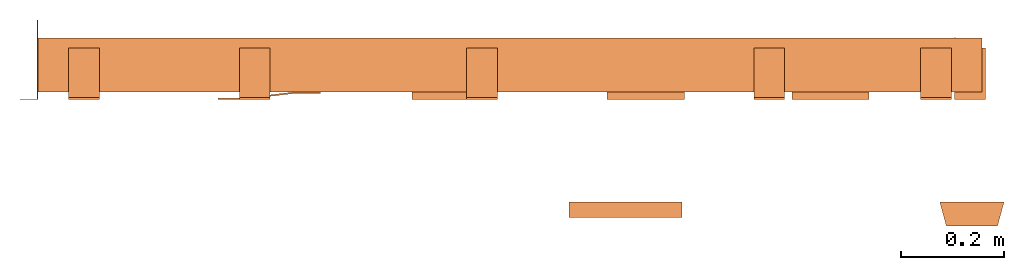
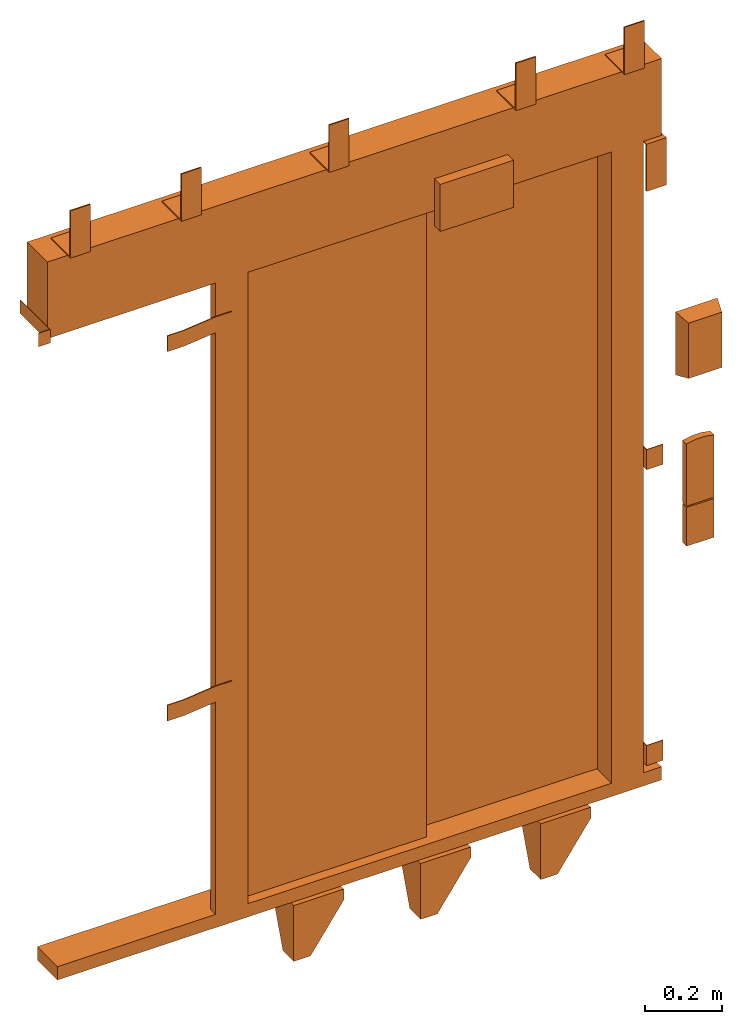
# One storey: 1 proxy.
"""IFC2X3 building model written with IfcOpenShell, lengths in millimetres."""

from ifc_helpers import new_model, entity, si_unit, converted_unit, derived_unit, direction, frame, origin, place, context, subcontext, project, spatial, faceted_brep, source, transform, mapped, material, type_object, type_shapes, element, save


model = new_model("IFC2X3")

# Units and contexts
model_context = context("Model", 3, precision=0.01, world=origin(), true_north=direction((6.12303176911189e-17, 1.0)))
body_context = subcontext(model_context, "Body", "Model", "MODEL_VIEW")
ifc_project = project(units=[si_unit("LENGTHUNIT", "METRE", prefix="MILLI"), si_unit("AREAUNIT", "SQUARE_METRE"), si_unit("VOLUMEUNIT", "CUBIC_METRE"), converted_unit("PLANEANGLEUNIT", "DEGREE", entity("IfcRatioMeasure", 0.0174532925199433), si_unit("PLANEANGLEUNIT", "RADIAN"), dimensions=[0, 0, 0, 0, 0, 0, 0]), si_unit("MASSUNIT", "GRAM", prefix="KILO"), derived_unit("MASSDENSITYUNIT", [(si_unit("MASSUNIT", "GRAM", prefix="KILO"), 1), (si_unit("LENGTHUNIT", "METRE"), -3)]), derived_unit("MOMENTOFINERTIAUNIT", [(si_unit("LENGTHUNIT", "METRE"), 4)]), si_unit("TIMEUNIT", "SECOND"), si_unit("FREQUENCYUNIT", "HERTZ"), si_unit("THERMODYNAMICTEMPERATUREUNIT", "DEGREE_CELSIUS"), derived_unit("THERMALTRANSMITTANCEUNIT", [(si_unit("MASSUNIT", "GRAM", prefix="KILO"), 1), (si_unit("THERMODYNAMICTEMPERATUREUNIT", "KELVIN"), -1), (si_unit("TIMEUNIT", "SECOND"), -3)]), derived_unit("VOLUMETRICFLOWRATEUNIT", [(si_unit("LENGTHUNIT", "METRE"), 3), (si_unit("TIMEUNIT", "SECOND"), -1)]), derived_unit("MASSFLOWRATEUNIT", [(si_unit("MASSUNIT", "GRAM", prefix="KILO"), 1), (si_unit("TIMEUNIT", "SECOND"), -1)]), derived_unit("ROTATIONALFREQUENCYUNIT", [(si_unit("TIMEUNIT", "SECOND"), -1)]), si_unit("ELECTRICCURRENTUNIT", "AMPERE"), si_unit("ELECTRICVOLTAGEUNIT", "VOLT"), si_unit("POWERUNIT", "WATT"), si_unit("FORCEUNIT", "NEWTON", prefix="KILO"), si_unit("ILLUMINANCEUNIT", "LUX"), si_unit("LUMINOUSFLUXUNIT", "LUMEN"), si_unit("LUMINOUSINTENSITYUNIT", "CANDELA"), derived_unit("USERDEFINED", [(si_unit("MASSUNIT", "GRAM", prefix="KILO"), -1), (si_unit("LENGTHUNIT", "METRE"), -2), (si_unit("TIMEUNIT", "SECOND"), 3), (si_unit("LUMINOUSFLUXUNIT", "LUMEN"), 1)]), derived_unit("LINEARVELOCITYUNIT", [(si_unit("LENGTHUNIT", "METRE"), 1), (si_unit("TIMEUNIT", "SECOND"), -1)]), si_unit("PRESSUREUNIT", "PASCAL"), derived_unit("USERDEFINED", [(si_unit("LENGTHUNIT", "METRE"), -2), (si_unit("MASSUNIT", "GRAM", prefix="KILO"), 1), (si_unit("TIMEUNIT", "SECOND"), -2)]), derived_unit("LINEARFORCEUNIT", [(si_unit("MASSUNIT", "GRAM", prefix="KILO"), 1), (si_unit("LENGTHUNIT", "METRE"), 1), (si_unit("TIMEUNIT", "SECOND"), -2), (si_unit("LENGTHUNIT", "METRE"), -1)]), derived_unit("PLANARFORCEUNIT", [(si_unit("MASSUNIT", "GRAM", prefix="KILO"), 1), (si_unit("LENGTHUNIT", "METRE"), 1), (si_unit("TIMEUNIT", "SECOND"), -2), (si_unit("LENGTHUNIT", "METRE"), -2)])], contexts=[model_context])

# Site, building, storey
site_placement = place(None, frame((0.0, -0.00077364408347762, 0.0)))
site = spatial("IfcSite", under=ifc_project, at=site_placement, CompositionType="ELEMENT")
building_placement = place(site_placement, origin())
building = spatial("IfcBuilding", under=site, at=building_placement, CompositionType="ELEMENT")
storey_placement = place(building_placement, frame((0.0, 0.0, 24000.0)))
storey = spatial("IfcBuildingStorey", under=building, at=storey_placement, CompositionType="ELEMENT", Elevation=24000.0)

# Proxy
ifc_material = material()
building_element_proxy_type = type_object("IfcBuildingElementProxyType", PredefinedType="NOTDEFINED", material=ifc_material)
shared_shape = source(origin(), body_context, "Body", "Brep", [
    faceted_brep([(11.6733435145681, 105.0, -47.0), (114.5, 33.0, -47.0), (114.5, 5.0, -47.0), (-31.0, 5.0, -47.0), (-31.0, 105.0, -47.0), (11.6733435145681, 105.0, -42.0), (-36.0, 105.0, -42.0), (-36.0, 0.0, -42.0), (114.5, 0.0, -42.0), (114.5, 33.0, -42.0), (-31.0, 105.0, -84.0), (-36.0, 105.0, -84.0), (-36.0, 55.8640183740635, -219.0), (-36.0, 0.0, -219.0), (114.5, 0.0, -76.185199325789), (114.5, 5.0, -76.185199325789), (14.5, 5.0, -219.0), (-31.0, 5.0, -219.0), (14.5, 0.0, -219.0), (-31.0, 55.8640183740635, -219.0)], [[[0, 1, 2, 3, 4]], [[5, 6, 7, 8, 9]], [[6, 5, 0, 4, 10, 11]], [[6, 11, 12, 13, 7]], [[2, 1, 9, 8, 14, 15]], [[1, 0, 5, 9]], [[15, 16, 17, 3, 2]], [[7, 13, 18, 14, 8]], [[16, 15, 14, 18]], [[18, 13, 12, 19, 17, 16]], [[19, 10, 4, 3, 17]], [[12, 11, 10, 19]]]),
    faceted_brep([(-1180.18717895667, 1.5, 2038.5), (-1180.18717895667, 0.0, 2038.5), (-1145.18717895667, 0.0, 2038.5), (-1145.18717895667, 155.0, 2038.5), (-1146.68717895667, 155.0, 2038.5), (-1146.68717895667, 1.5, 2038.5), (-1180.18717895667, 1.5, 1995.5), (-1146.68717895667, 1.5, 1995.5), (-1146.68717895667, 155.0, 1995.5), (-1145.18717895667, 155.0, 1995.5), (-1145.18717895667, 0.0, 1995.5), (-1180.18717895667, 0.0, 1995.5)], [[[0, 1, 2, 3, 4, 5]], [[6, 7, 8, 9, 10, 11]], [[1, 0, 6, 11]], [[2, 1, 11, 10]], [[3, 2, 10, 9]], [[4, 3, 9, 8]], [[5, 4, 8, 7]], [[0, 5, 7, 6]]]),
    faceted_brep([(-794.0935894783, 3.0, 1895.0), (-794.0935894783, 0.0, 1895.0), (-744.093589478302, 0.0, 1895.0), (-644.0935894783, 12.0, 1895.0), (-594.0935894783, 12.0, 1895.0), (-594.0935894783, 15.0, 1895.0), (-644.093589478299, 15.0, 1895.0), (-744.0935894783, 3.0, 1895.0), (-794.0935894783, 3.0, 1845.0), (-744.0935894783, 3.0, 1845.0), (-644.093589478299, 15.0, 1845.0), (-594.0935894783, 15.0, 1845.0), (-594.0935894783, 12.0, 1845.0), (-644.0935894783, 12.0, 1845.0), (-744.093589478302, 0.0, 1845.0), (-794.0935894783, 0.0, 1845.0)], [[[0, 1, 2, 3, 4, 5, 6, 7]], [[8, 9, 10, 11, 12, 13, 14, 15]], [[1, 0, 8, 15]], [[2, 1, 15, 14]], [[3, 2, 14, 13]], [[4, 3, 13, 12]], [[5, 4, 12, 11]], [[6, 5, 11, 10]], [[7, 6, 10, 9]], [[0, 7, 9, 8]]]),
    faceted_brep([(-794.0935894783, 3.0, 725.0), (-794.0935894783, 0.0, 725.0), (-744.093589478302, 0.0, 725.0), (-644.0935894783, 12.0, 725.0), (-594.0935894783, 12.0, 725.0), (-594.0935894783, 15.0, 725.0), (-644.093589478299, 15.0, 725.0), (-744.0935894783, 3.0, 725.0), (-794.0935894783, 3.0, 675.0), (-744.0935894783, 3.0, 675.0), (-644.093589478299, 15.0, 675.0), (-594.0935894783, 15.0, 675.0), (-594.0935894783, 12.0, 675.0), (-644.0935894783, 12.0, 675.0), (-744.093589478302, 0.0, 675.0), (-794.0935894783, 0.0, 675.0)], [[[0, 1, 2, 3, 4, 5, 6, 7]], [[8, 9, 10, 11, 12, 13, 14, 15]], [[1, 0, 8, 15]], [[2, 1, 15, 14]], [[3, 2, 14, 13]], [[4, 3, 13, 12]], [[5, 4, 12, 11]], [[6, 5, 11, 10]], [[7, 6, 10, 9]], [[0, 7, 9, 8]]]),
    faceted_brep([(641.093589478243, 121.0, 95.0), (641.093589478243, 0.0, 95.0), (691.093589478243, 0.0, 95.0), (691.093589478243, 2.0, 95.0), (643.093589478243, 2.0, 95.0), (643.093589478243, 121.0, 95.0), (641.093589478243, 121.0, 31.0), (643.093589478243, 121.0, 31.0), (643.093589478243, 2.0, 31.0), (691.093589478243, 2.0, 31.0), (691.093589478243, 0.0, 31.0), (641.093589478243, 0.0, 31.0)], [[[0, 1, 2, 3, 4, 5]], [[6, 7, 8, 9, 10, 11]], [[1, 0, 6, 11]], [[2, 1, 11, 10]], [[3, 2, 10, 9]], [[4, 3, 9, 8]], [[5, 4, 8, 7]], [[0, 5, 7, 6]]]),
    faceted_brep([(641.093589478243, 121.0, 1032.0), (641.093589478243, 0.0, 1032.0), (691.093589478243, 0.0, 1032.0), (691.093589478243, 2.0, 1032.0), (643.093589478243, 2.0, 1032.0), (643.093589478243, 121.0, 1032.0), (641.093589478243, 121.0, 968.0), (643.093589478243, 121.0, 968.0), (643.093589478243, 2.0, 968.0), (691.093589478243, 2.0, 968.0), (691.093589478243, 0.0, 968.0), (641.093589478243, 0.0, 968.0)], [[[0, 1, 2, 3, 4, 5]], [[6, 7, 8, 9, 10, 11]], [[1, 0, 6, 11]], [[2, 1, 11, 10]], [[3, 2, 10, 9]], [[4, 3, 9, 8]], [[5, 4, 8, 7]], [[0, 5, 7, 6]]]),
    faceted_brep([(371.76693299286, 105.0, -47.0), (474.593589478292, 33.0, -47.0), (474.593589478292, 5.0, -47.0), (329.093589478292, 5.0, -47.0), (329.093589478293, 105.0, -47.0), (371.76693299286, 105.0, -42.0), (324.093589478293, 105.0, -42.0), (324.093589478292, 0.0, -42.0), (474.593589478292, 0.0, -42.0), (474.593589478292, 33.0, -42.0), (329.093589478293, 105.0, -84.0), (324.093589478293, 105.0, -84.0), (324.093589478292, 55.8640183740593, -219.0), (324.093589478293, 0.0, -219.0), (474.593589478292, 0.0, -76.185199325789), (474.593589478292, 5.0, -76.185199325789), (374.593589478292, 5.0, -219.0), (329.093589478292, 5.0, -219.0), (374.593589478292, 0.0, -219.0), (329.093589478292, 55.8640183740593, -219.0)], [[[0, 1, 2, 3, 4]], [[5, 6, 7, 8, 9]], [[6, 5, 0, 4, 10, 11]], [[6, 11, 12, 13, 7]], [[2, 1, 9, 8, 14, 15]], [[1, 0, 5, 9]], [[15, 16, 17, 3, 2]], [[7, 13, 18, 14, 8]], [[16, 15, 14, 18]], [[18, 13, 12, 19, 17, 16]], [[19, 10, 4, 3, 17]], [[12, 11, 10, 19]]]),
    faceted_brep([(-368.420245963724, 105.0, -47.0), (-265.593589478292, 33.0, -47.0), (-265.593589478292, 5.0, -47.0), (-411.093589478292, 5.0, -47.0), (-411.093589478292, 105.0, -47.0), (-368.420245963724, 105.0, -42.0), (-416.093589478292, 105.0, -42.0), (-416.093589478292, 0.0, -42.0), (-265.593589478293, 0.0, -42.0), (-265.593589478292, 33.0, -42.0), (-411.093589478292, 105.0, -84.0), (-416.093589478292, 105.0, -84.0), (-416.093589478292, 55.864018374066, -219.0), (-416.093589478292, 0.0, -219.0), (-265.593589478292, 0.0, -76.185199325789), (-265.593589478292, 5.0, -76.185199325789), (-365.593589478292, 5.0, -219.0), (-411.093589478292, 5.0, -219.0), (-365.593589478292, 0.0, -219.0), (-411.093589478292, 55.864018374066, -219.0)], [[[0, 1, 2, 3, 4]], [[5, 6, 7, 8, 9]], [[6, 5, 0, 4, 10, 11]], [[6, 11, 12, 13, 7]], [[2, 1, 9, 8, 14, 15]], [[1, 0, 5, 9]], [[15, 16, 17, 3, 2]], [[7, 13, 18, 14, 8]], [[16, 15, 14, 18]], [[18, 13, 12, 19, 17, 16]], [[19, 10, 4, 3, 17]], [[12, 11, 10, 19]]]),
    faceted_brep([(701.093589478243, 100.0, 2000.0), (701.093589478243, 0.0, 2000.0), (701.093589478243, 0.0, 1850.0), (701.093589478243, 4.0, 1850.0), (701.093589478243, 4.0, 1996.0), (701.093589478243, 100.0, 1996.0), (641.093589478243, 100.0, 2000.0), (641.093589478243, 100.0, 1996.0), (641.093589478243, 4.0, 1996.0), (641.093589478243, 4.0, 1850.0), (641.093589478243, 0.0, 1850.0), (641.093589478243, 0.0, 2000.0)], [[[0, 1, 2, 3, 4, 5]], [[6, 7, 8, 9, 10, 11]], [[1, 0, 6, 11]], [[2, 1, 11, 10]], [[3, 2, 10, 9]], [[4, 3, 9, 8]], [[5, 4, 8, 7]], [[0, 5, 7, 6]]]),
    faceted_brep([(635.093589478254, 100.0, 2247.0), (635.093589478254, 4.0, 2247.0), (635.093589478254, 4.0, 2393.0), (635.093589478254, 0.0, 2393.0), (635.093589478254, 0.0, 2243.0), (635.093589478254, 100.0, 2243.0), (575.093589478254, 100.0, 2247.0), (575.093589478254, 100.0, 2243.0), (575.093589478254, 0.0, 2243.0), (575.093589478254, 0.0, 2393.0), (575.093589478254, 4.0, 2393.0), (575.093589478254, 4.0, 2247.0)], [[[0, 1, 2, 3, 4, 5]], [[6, 7, 8, 9, 10, 11]], [[1, 0, 6, 11]], [[2, 1, 11, 10]], [[3, 2, 10, 9]], [[4, 3, 9, 8]], [[5, 4, 8, 7]], [[0, 5, 7, 6]]]),
    faceted_brep([(-250.0, 100.0, 2247.0), (-250.0, 4.0, 2247.0), (-250.0, 4.0, 2393.0), (-250.0, 0.0, 2393.0), (-250.0, 0.0, 2243.0), (-250.0, 100.0, 2243.0), (-310.0, 100.0, 2247.0), (-310.0, 100.0, 2243.0), (-310.0, 0.0, 2243.0), (-310.0, 0.0, 2393.0), (-310.0, 4.0, 2393.0), (-310.0, 4.0, 2247.0)], [[[0, 1, 2, 3, 4, 5]], [[6, 7, 8, 9, 10, 11]], [[1, 0, 6, 11]], [[2, 1, 11, 10]], [[3, 2, 10, 9]], [[4, 3, 9, 8]], [[5, 4, 8, 7]], [[0, 5, 7, 6]]]),
    faceted_brep([(-692.5, 100.0, 2247.0), (-692.5, 4.0, 2247.0), (-692.5, 4.0, 2393.0), (-692.5, 0.0, 2393.0), (-692.5, 0.0, 2243.0), (-692.5, 100.0, 2243.0), (-752.5, 100.0, 2247.0), (-752.5, 100.0, 2243.0), (-752.5, 0.0, 2243.0), (-752.5, 0.0, 2393.0), (-752.5, 4.0, 2393.0), (-752.5, 4.0, 2247.0)], [[[0, 1, 2, 3, 4, 5]], [[6, 7, 8, 9, 10, 11]], [[1, 0, 6, 11]], [[2, 1, 11, 10]], [[3, 2, 10, 9]], [[4, 3, 9, 8]], [[5, 4, 8, 7]], [[0, 5, 7, 6]]]),
    faceted_brep([(-1025.1871789567, 100.0, 2247.0), (-1025.1871789567, 4.0, 2247.0), (-1025.1871789567, 4.0, 2393.0), (-1025.1871789567, 0.0, 2393.0), (-1025.1871789567, 0.0, 2243.0), (-1025.1871789567, 100.0, 2243.0), (-1085.1871789567, 100.0, 2247.0), (-1085.1871789567, 100.0, 2243.0), (-1085.1871789567, 0.0, 2243.0), (-1085.1871789567, 0.0, 2393.0), (-1085.1871789567, 4.0, 2393.0), (-1085.1871789567, 4.0, 2247.0)], [[[0, 1, 2, 3, 4, 5]], [[6, 7, 8, 9, 10, 11]], [[1, 0, 6, 11]], [[2, 1, 11, 10]], [[3, 2, 10, 9]], [[4, 3, 9, 8]], [[5, 4, 8, 7]], [[0, 5, 7, 6]]]),
    faceted_brep([(310.0, 100.0, 2247.0), (310.0, 4.0, 2247.0), (310.0, 4.0, 2393.0), (310.0, 0.0, 2393.0), (310.0, 0.0, 2243.0), (310.0, 100.0, 2243.0), (250.0, 100.0, 2247.0), (250.0, 100.0, 2243.0), (250.0, 0.0, 2243.0), (250.0, 0.0, 2393.0), (250.0, 4.0, 2393.0), (250.0, 4.0, 2247.0)], [[[0, 1, 2, 3, 4, 5]], [[6, 7, 8, 9, 10, 11]], [[1, 0, 6, 11]], [[2, 1, 11, 10]], [[3, 2, 10, 9]], [[4, 3, 9, 8]], [[5, 4, 8, 7]], [[0, 5, 7, 6]]]),
    faceted_brep([(725.093589478309, -246.0, 1587.5), (625.093589478309, -246.0, 1587.5), (625.093589478309, -246.0, 1412.5), (725.093589478309, -246.0, 1412.5), (737.593589478309, -200.0, 1600.0), (737.593589478309, -200.0, 1400.0), (612.593589478309, -200.0, 1400.0), (612.593589478309, -200.0, 1600.0)], [[[0, 1, 2, 3]], [[4, 5, 6, 7]], [[4, 7, 1, 0]], [[7, 6, 2, 1]], [[6, 5, 3, 2]], [[5, 4, 0, 3]]]),
    faceted_brep([(716.593589478309, -220.0, 985.0), (633.593589478309, -220.0, 985.0), (633.593589478309, -220.0, 862.0), (716.593589478309, -220.0, 862.0), (716.593589478309, -200.0, 985.0), (716.593589478309, -200.0, 862.0), (633.593589478309, -200.0, 862.0), (633.593589478309, -200.0, 985.0)], [[[0, 1, 2, 3]], [[4, 5, 6, 7]], [[1, 0, 4, 7]], [[2, 1, 7, 6]], [[3, 2, 6, 5]], [[0, 3, 5, 4]]]),
    faceted_brep([(110.0, -200.0, 2274.49999999999), (110.0, -200.0, 2125.49999999999), (-110.0, -200.0, 2125.49999999999), (-110.0, -200.0, 2274.49999999999), (110.0, -230.0, 2274.49999999999), (-110.0, -230.0, 2274.49999999999), (-110.0, -230.0, 2125.49999999999), (110.0, -230.0, 2125.49999999999)], [[[0, 1, 2, 3]], [[4, 5, 6, 7]], [[5, 4, 0, 3]], [[6, 5, 3, 2]], [[7, 6, 2, 1]], [[4, 7, 1, 0]]]),
    faceted_brep([(689.089383715606, -220.0, 1191.34563181984), (661.097795241014, -220.0, 1191.34563181984), (633.59358947831, -220.0, 1186.14489238263), (633.593589478309, -220.0, 989.0), (716.593589478308, -220.0, 989.0), (716.593589478309, -220.0, 1186.14489238263), (716.593589478308, -200.0, 1186.14489238263), (716.593589478308, -200.0, 989.0), (633.593589478309, -200.0, 989.0), (633.593589478311, -200.0, 1186.14489238263), (661.097795241014, -200.0, 1191.34563181984), (689.089383715606, -200.0, 1191.34563181984)], [[[0, 1, 2, 3, 4, 5]], [[6, 7, 8, 9, 10, 11]], [[3, 2, 9, 8]], [[4, 3, 8, 7]], [[5, 4, 7, 6]], [[6, 11, 0, 5]], [[11, 10, 1, 0]], [[10, 9, 2, 1]]]),
    faceted_brep([(545.093589478292, 87.0, 2000.0), (545.093589478292, 15.0, 2000.0), (641.093589478243, 15.0, 2000.0), (641.093589478243, 120.0, 2000.0), (564.093589478279, 120.0, 2000.0), (564.093589478279, 87.0, 2000.0), (545.093589478292, 87.0, 0.0), (545.093589478292, 15.0, 0.0), (641.093589478243, 15.0, 0.0), (641.093589478243, 120.0, 0.0), (564.093589478279, 120.0, 0.0), (564.093589478279, 87.0, 0.0)], [[[0, 1, 2, 3, 4, 5]], [[1, 0, 6, 7]], [[2, 1, 7, 8]], [[3, 2, 8, 9]], [[4, 3, 9, 10]], [[5, 4, 10, 11]], [[0, 5, 11, 6]], [[6, 11, 10, 9, 8, 7]]]),
    faceted_brep([(-545.093589478292, 41.0, 0.0), (-545.093589478292, 15.0, 0.0), (-641.0935894783, 15.0, 0.0), (-641.0935894783, 41.0, 0.0), (-641.0935894783, 41.0, 2000.0), (-545.093589478292, 41.0, 2000.0), (-641.0935894783, 15.0, 2000.0), (-545.093589478292, 15.0, 2000.0)], [[[0, 1, 2, 3]], [[4, 5, 0, 3]], [[6, 4, 3, 2]], [[7, 6, 2, 1]], [[5, 7, 1, 0]], [[5, 4, 6, 7]]]),
    faceted_brep([(695.09358947826, 15.0, 0.0), (695.09358947826, 15.0, -42.0), (695.09358947826, 120.0, -42.0), (695.09358947826, 120.0, 0.0), (-1115.18717895646, 15.0, 0.0), (-1115.18717895646, 120.0, 0.0), (-1115.18717895646, 120.0, -42.0), (-1115.18717895646, 15.0, -42.0)], [[[0, 1, 2, 3]], [[4, 5, 6, 7]], [[1, 0, 4, 7]], [[2, 1, 7, 6]], [[3, 2, 6, 5]], [[0, 3, 5, 4]]]),
    faceted_brep([(695.09358947826, 15.0, 2243.0), (695.09358947826, 15.0, 2000.0), (695.09358947826, 120.0, 2000.0), (695.09358947826, 120.0, 2243.0), (-1145.18717895667, 15.0, 2243.0), (-1145.18717895667, 120.0, 2243.0), (-1145.18717895667, 120.0, 2000.0), (-1145.18717895667, 15.0, 2000.0)], [[[0, 1, 2, 3]], [[4, 5, 6, 7]], [[1, 0, 4, 7]], [[2, 1, 7, 6]], [[3, 2, 6, 5]], [[0, 3, 5, 4]]]),
    faceted_brep([(560.093589478281, 120.0, 2000.0), (-22.0, 120.0, 2000.0), (-22.0, 91.0, 2000.0), (560.093589478281, 91.0, 2000.0), (560.093589478281, 120.0, 0.0), (-22.0, 120.0, 0.0), (-22.0, 91.0, 0.0), (560.093589478281, 91.0, 0.0)], [[[0, 1, 2, 3]], [[1, 0, 4, 5]], [[2, 1, 5, 6]], [[3, 2, 6, 7]], [[0, 3, 7, 4]], [[4, 7, 6, 5]]]),
    faceted_brep([(8.0, 87.0, 0.0), (8.0, 45.0, 0.0), (-575.093589478304, 45.0, 0.0), (-575.093589478304, 87.0, 0.0), (-575.093589478304, 87.0, 2000.0), (8.0, 87.0, 2000.0), (-575.093589478304, 45.0, 2000.0), (8.0, 45.0, 2000.0)], [[[0, 1, 2, 3]], [[4, 5, 0, 3]], [[6, 4, 3, 2]], [[7, 6, 2, 1]], [[5, 7, 1, 0]], [[5, 4, 6, 7]]]),
])
type_shapes(building_element_proxy_type, [shared_shape])
proxy_placement = place(storey_placement, frame((70118.1531562274, 14140.0, 0.0)))
element("IfcBuildingElementProxy", 1, at=proxy_placement, inside=storey, type_object=building_element_proxy_type, material=ifc_material, context=body_context, shape_type="MappedRepresentation", body=[
    mapped(shared_shape, transform((0.0, 0.0, 0.0), scale=1.0)),
])

save(model, "model.ifc")
